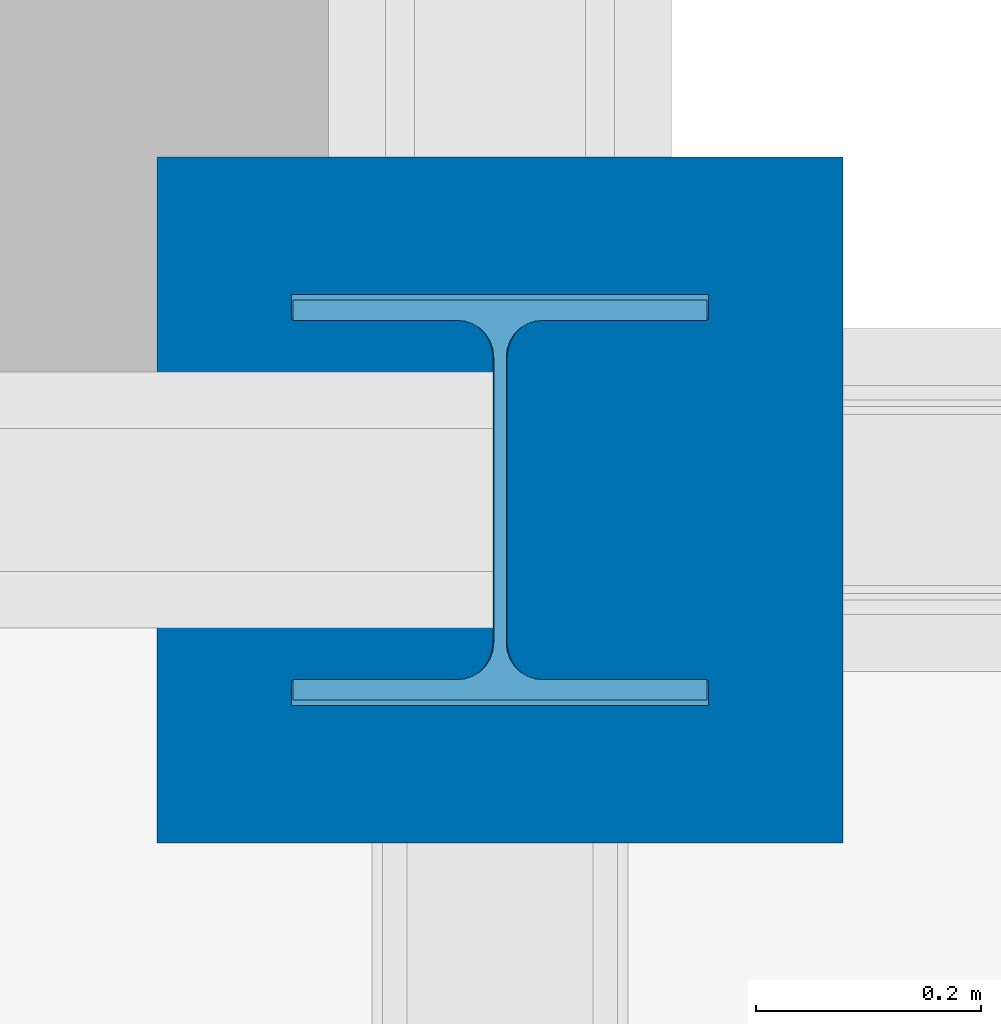
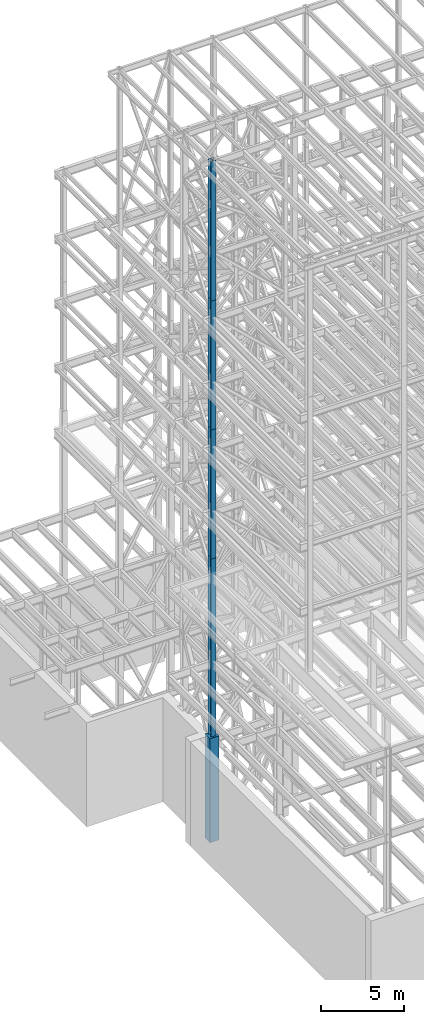
# One storey, part 10 of 150: 5 columns.
"""IFC2X3 building model written with IfcOpenShell, lengths in millimetres."""

from ifc_helpers import new_model, si_unit, frame, origin_with_axes, origin_2d_with_axis, place, context, subcontext, project, spatial, rectangle, i_section, extrude, material, type_object, element, save


model = new_model("IFC2X3")

# Units and contexts
model_context = context("Model", 3, precision=1e-05, world=origin_with_axes())
body_context = subcontext(model_context, "Body", "Model", "MODEL_VIEW")
ifc_project = project(units=[si_unit("LENGTHUNIT", "METRE", prefix="MILLI"), si_unit("AREAUNIT", "SQUARE_METRE"), si_unit("VOLUMEUNIT", "CUBIC_METRE"), si_unit("MASSUNIT", "GRAM", prefix="KILO"), si_unit("TIMEUNIT", "SECOND"), si_unit("PLANEANGLEUNIT", "RADIAN"), si_unit("SOLIDANGLEUNIT", "STERADIAN"), si_unit("THERMODYNAMICTEMPERATUREUNIT", "DEGREE_CELSIUS"), si_unit("LUMINOUSINTENSITYUNIT", "LUMEN")], contexts=[model_context])

# Site, building, storey
site_placement = place(None, origin_with_axes())
site = spatial("IfcSite", under=ifc_project, at=site_placement, CompositionType="ELEMENT")
building_placement = place(site_placement, origin_with_axes())
building = spatial("IfcBuilding", under=site, at=building_placement, Name="Undefined", CompositionType="ELEMENT")
storey_placement = place(building_placement, origin_with_axes())
storey = spatial("IfcBuildingStorey", under=building, at=storey_placement, Name="Undefined", CompositionType="ELEMENT", Elevation=0.0)

# Columns
ifc_material_1 = material(Name="STEEL/A992")
column_type_1 = type_object("IfcColumnType", Name="W14X90", PredefinedType="NOTDEFINED")
column_1_placement = place(storey_placement, frame((5283.2, 21043.9, 55702.2), z_axis=(0.0, 0.0, 1.0), x_axis=(1.0, 0.0, 0.0)))
element("IfcColumn", 1, at=column_1_placement, inside=storey, type_object=column_type_1, material=ifc_material_1, Name="COLUMN", ObjectType="W14X90", context=body_context, shape_type="SweptSolid", body=[
    extrude(i_section(OverallWidth=368.3, OverallDepth=355.6, WebThickness=11.1125, FlangeThickness=18.034, FilletRadius=32.7659, at=origin_2d_with_axis()), frame((0.0, 0.0, 10210.8), z_axis=(0.0, 0.0, -1.0), x_axis=(-1.0, 0.0, 0.0)), (0.0, 0.0, 1.0), 10210.8),
])
for number, where, z_axis, x_axis, name in (
    (2, (5283.2, 21043.9, 46253.4), (0.0, 0.0, 1.0), (1.0, 0.0, 0.0), "COLUMN"),
    (3, (5283.2, 21043.9, 36804.6), (0.0, 0.0, 1.0), (1.0, 0.0, 0.0), "COLUMN"),
):
    element("IfcColumn", number, at=place(storey_placement, frame(where, z_axis=z_axis, x_axis=x_axis)), inside=storey, type_object=column_type_1, material=ifc_material_1, Name=name, ObjectType="W14X90", context=body_context, shape_type="SweptSolid", body=[
        extrude(i_section(OverallWidth=368.3, OverallDepth=355.6, WebThickness=11.1125, FlangeThickness=18.034, FilletRadius=32.7659, at=origin_2d_with_axis()), frame((0.0, 0.0, 9448.8), z_axis=(0.0, 0.0, -1.0), x_axis=(-1.0, 0.0, 0.0)), (0.0, 0.0, 1.0), 9448.8),
    ])
column_type_2 = type_object("IfcColumnType", Name="W14X109", PredefinedType="NOTDEFINED")
column_2_placement = place(storey_placement, frame((5283.2, 21043.9, 22707.6), z_axis=(0.0, 0.0, 1.0), x_axis=(1.0, 0.0, 0.0)))
element("IfcColumn", 4, at=column_2_placement, inside=storey, type_object=column_type_2, material=ifc_material_1, Name="COLUMN", ObjectType="W14X109", context=body_context, shape_type="SweptSolid", body=[
    extrude(i_section(OverallWidth=370.84, OverallDepth=365.125, WebThickness=12.6999, FlangeThickness=21.844, FilletRadius=33.7184, at=origin_2d_with_axis()), frame((0.0, 0.0, 14097.0), z_axis=(0.0, 0.0, -1.0), x_axis=(-1.0, 0.0, 0.0)), (0.0, 0.0, 1.0), 14097.0),
])
ifc_material_2 = material(Name="CONCRETE/5000")
column_type_3 = type_object("IfcColumnType", PredefinedType="NOTDEFINED")
column_3_placement = place(storey_placement, frame((5283.2, 21043.9, 16154.4), z_axis=(0.0, 0.0, 1.0), x_axis=(1.0, 0.0, 0.0)))
element("IfcColumn", 5, at=column_3_placement, inside=storey, type_object=column_type_3, material=ifc_material_2, Name="COLUMN", context=body_context, shape_type="SweptSolid", body=[
    extrude(rectangle(XDim=609.6, YDim=609.6, at=origin_2d_with_axis()), frame((0.0, 0.0, 7620.0), z_axis=(0.0, 0.0, -1.0), x_axis=(0.0, -1.0, 0.0)), (0.0, 0.0, 1.0), 7620.0),
])

save(model, "model.ifc")
